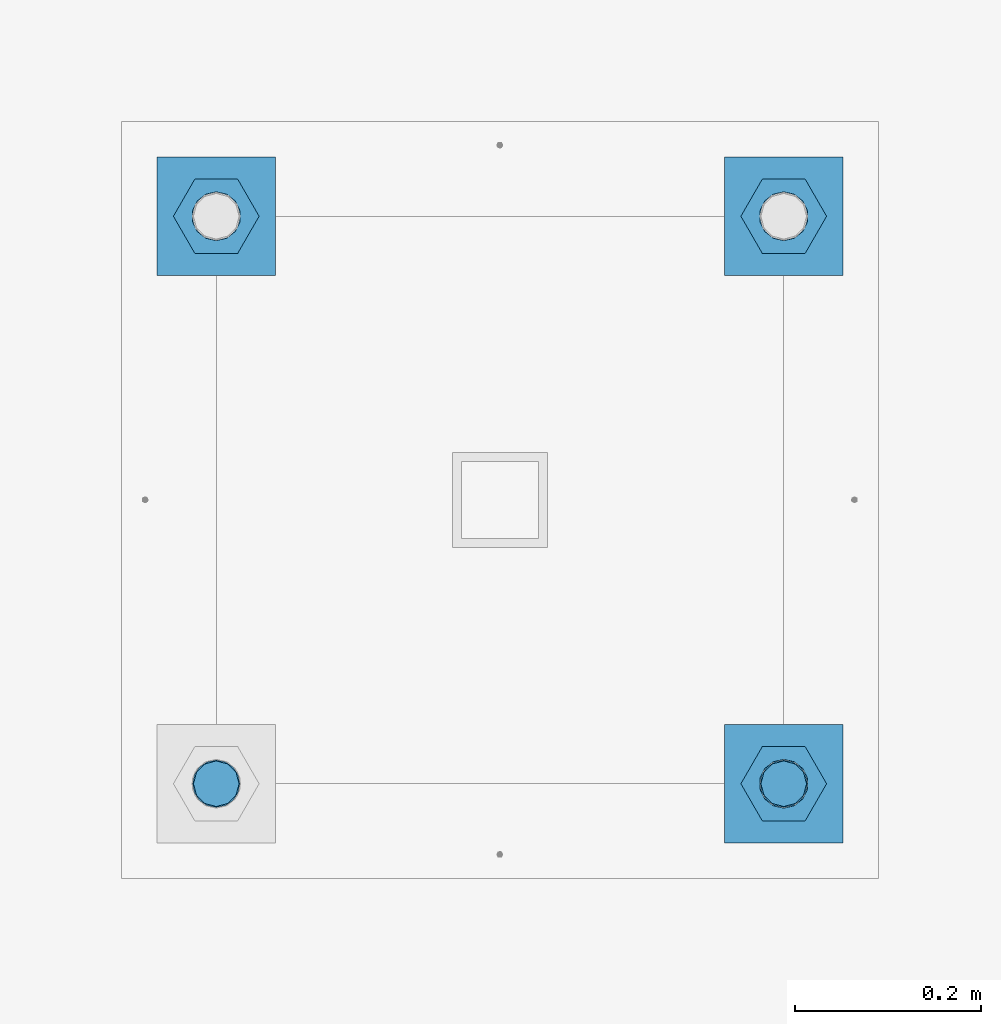
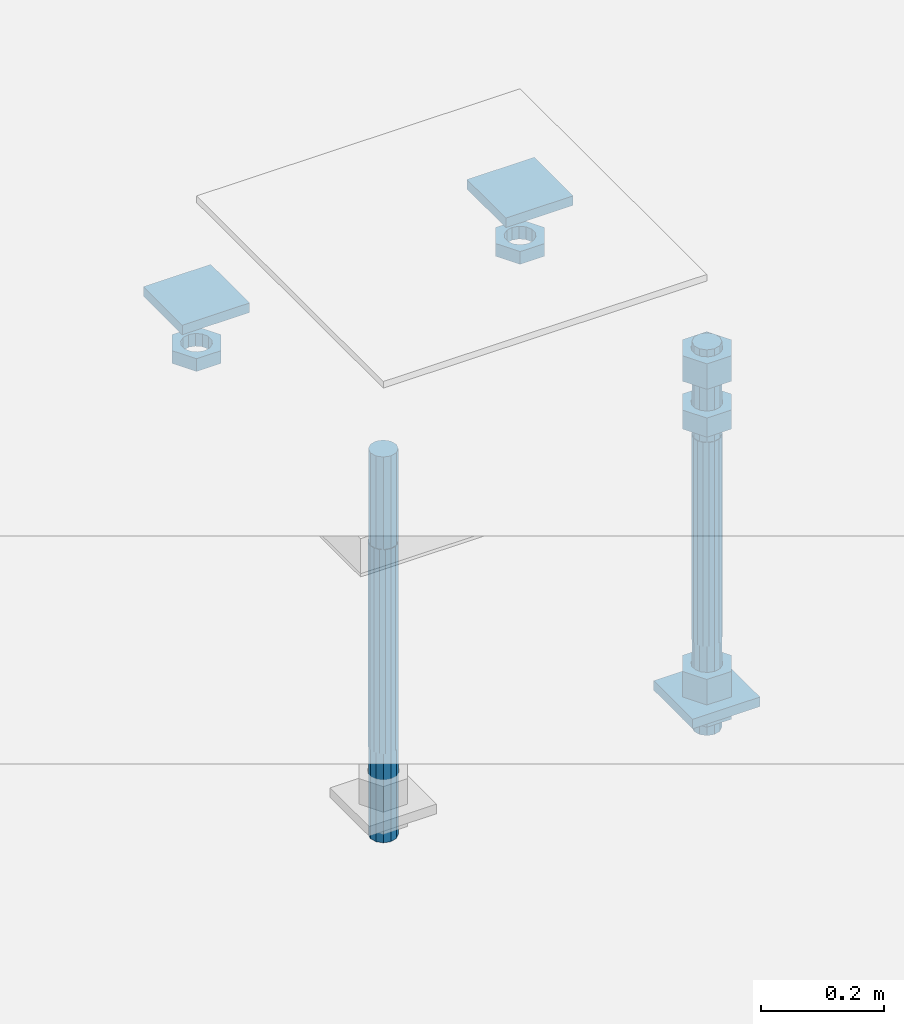
# One storey, part 2714 of 3843: 11 beams, 1 element without a shape of its own.
"""IFC2X3 building model written with IfcOpenShell, lengths in millimetres."""

from ifc_helpers import new_model, si_unit, frame, origin_with_axes, place, context, subcontext, project, spatial, faceted_brep, material, type_object, element, aggregate, save


model = new_model("IFC2X3")

# Units and contexts
model_context = context("Model", 3, precision=1e-05, world=origin_with_axes())
body_context = subcontext(model_context, "Body", "Model", "MODEL_VIEW")
ifc_project = project(units=[si_unit("LENGTHUNIT", "METRE", prefix="MILLI"), si_unit("AREAUNIT", "SQUARE_METRE"), si_unit("VOLUMEUNIT", "CUBIC_METRE"), si_unit("MASSUNIT", "GRAM", prefix="KILO"), si_unit("TIMEUNIT", "SECOND"), si_unit("PLANEANGLEUNIT", "RADIAN"), si_unit("SOLIDANGLEUNIT", "STERADIAN"), si_unit("THERMODYNAMICTEMPERATUREUNIT", "DEGREE_CELSIUS"), si_unit("LUMINOUSINTENSITYUNIT", "LUMEN")], contexts=[model_context])

# Site, building, storey
site_placement = place(None, origin_with_axes())
site = spatial("IfcSite", under=ifc_project, at=site_placement, CompositionType="ELEMENT")
building_placement = place(site_placement, origin_with_axes())
building = spatial("IfcBuilding", under=site, at=building_placement, Name="Undefined", CompositionType="ELEMENT")
storey_placement = place(building_placement, origin_with_axes())
storey = spatial("IfcBuildingStorey", under=building, at=storey_placement, Name="Undefined", CompositionType="ELEMENT", Elevation=0.0)

# Assembly, beams
assembly_placement = place(storey_placement, origin_with_axes())
assembly = element("IfcElementAssembly", 1, at=assembly_placement, inside=storey, Name="TEMPLATE", AssemblyPlace="NOTDEFINED", PredefinedType="RIGID_FRAME")
ifc_material_1 = material(Name="STEEL/A36")
beam_type_1 = type_object("IfcBeamType", PredefinedType="NOTDEFINED")
beam_1_placement = place(assembly_placement, frame((108648.5, 48869.6000015259, 29873.575), z_axis=(1.0, 0.0, 0.0), x_axis=(0.0, 1.0, 0.0)))
beam_1 = element("IfcBeam", 2, at=beam_1_placement, type_object=beam_type_1, material=ifc_material_1, Name="WASHER_PLATE", context=body_context, shape_type="Brep", body=[
    faceted_brep([(0.0, 9.52500000000146, -63.5), (0.0, 9.52500000000146, 63.5), (127.0, 9.52500000000146, 63.5), (127.0, 9.52500000000146, -63.5), (0.0, -9.52500000000146, 63.5), (127.0, -9.52500000000146, 63.5), (0.0, -9.52500000000146, -63.5), (127.0, -9.52500000000146, -63.5)], [[[0, 1, 2, 3]], [[1, 4, 5, 2]], [[4, 6, 7, 5]], [[6, 0, 3, 7]], [[5, 7, 3, 2]], [[6, 4, 1, 0]]]),
])
beam_2_placement = place(assembly_placement, frame((109258.1, 48869.6000015259, 29873.575), z_axis=(1.0, 0.0, 0.0), x_axis=(0.0, 1.0, 0.0)))
beam_2 = element("IfcBeam", 3, at=beam_2_placement, type_object=beam_type_1, material=ifc_material_1, Name="WASHER_PLATE", context=body_context, shape_type="Brep", body=[
    faceted_brep([(0.0, 9.52500000000146, -63.5), (0.0, 9.52500000000146, 63.5), (127.0, 9.52500000000146, 63.5), (127.0, 9.52500000000146, -63.5), (0.0, -9.52500000000146, 63.5), (127.0, -9.52500000000146, 63.5), (0.0, -9.52500000000146, -63.5), (127.0, -9.52500000000146, -63.5)], [[[0, 1, 2, 3]], [[1, 4, 5, 2]], [[4, 6, 7, 5]], [[6, 0, 3, 7]], [[5, 7, 3, 2]], [[6, 4, 1, 0]]]),
])
beam_3_placement = place(assembly_placement, frame((109258.1, 48260.0000015259, 29244.925), z_axis=(1.0, 0.0, 0.0), x_axis=(0.0, 1.0, 0.0)))
beam_3 = element("IfcBeam", 4, at=beam_3_placement, type_object=beam_type_1, material=ifc_material_1, Name="WASHER_PLATE", context=body_context, shape_type="Brep", body=[
    faceted_brep([(0.0, 9.52500000000146, -63.5), (0.0, 9.52500000000146, 63.5), (127.0, 9.52500000000146, 63.5), (127.0, 9.52500000000146, -63.5), (0.0, -9.52500000000146, 63.5), (127.0, -9.52500000000146, 63.5), (0.0, -9.52500000000146, -63.5), (127.0, -9.52500000000146, -63.5)], [[[0, 1, 2, 3]], [[1, 4, 5, 2]], [[4, 6, 7, 5]], [[6, 0, 3, 7]], [[5, 7, 3, 2]], [[6, 4, 1, 0]]]),
])
beam_type_2 = type_object("IfcBeamType", Name="2_HALF_NUT", PredefinedType="NOTDEFINED")
beam_4_placement = place(assembly_placement, frame((108648.5, 48933.1000015259, 29787.85), z_axis=(0.0, 1.0, 0.0), x_axis=(0.0, 0.0, -1.0)))
beam_4 = element("IfcBeam", 5, at=beam_4_placement, type_object=beam_type_2, material=ifc_material_1, Name="NUT", ObjectType="2_HALF_NUT", context=body_context, shape_type="Brep", body=[
    faceted_brep([(0.0, -46.0369987487793, 0.0), (0.0, -23.0184993743896, -39.869213104248), (25.4000000000015, -23.0184993743896, -39.869213104248), (25.4000000000015, -46.0369987487793, 0.0), (0.0, 23.0184993743896, -39.869213104248), (25.4000000000015, 23.0184993743896, -39.869213104248), (0.0, 46.0369987487793, 0.0), (25.4000000000015, 46.0369987487793, 0.0), (0.0, 23.0184993743896, 39.869213104248), (25.4000000000015, 23.0184993743896, 39.869213104248), (0.0, -23.0184993743896, 39.869213104248), (25.4000000000015, -23.0184993743896, 39.869213104248), (0.0, 0.0, 26.1940002441406), (0.0, 11.3650617044477, 23.5999013092805), (25.4000000000015, 11.3650617044477, 23.5999013092805), (25.4000000000015, 0.0, 26.1940002441406), (0.0, 20.4791109456419, 16.3316083006721), (25.4000000000015, 20.4791109456419, 16.3316083006721), (0.0, 25.5370200498292, 5.82867859874386), (25.4000000000015, 25.5370200498292, 5.82867859874386), (0.0, 25.5370200498292, -5.82867859874386), (25.4000000000015, 25.5370200498292, -5.82867859874386), (0.0, 20.4791109456419, -16.3316083006721), (25.4000000000015, 20.4791109456419, -16.3316083006721), (0.0, 11.3650617044477, -23.5999013092805), (25.4000000000015, 11.3650617044477, -23.5999013092805), (0.0, 0.0, -26.1940002441406), (25.4000000000015, 0.0, -26.1940002441406), (0.0, -11.3650617044477, -23.5999013092805), (25.4000000000015, -11.3650617044477, -23.5999013092805), (0.0, -20.4791109456419, -16.3316083006721), (25.4000000000015, -20.4791109456419, -16.3316083006721), (0.0, -25.5370200498292, -5.82867859874386), (25.4000000000015, -25.5370200498292, -5.82867859874386), (0.0, -25.5370200498292, 5.82867859874386), (25.4000000000015, -25.5370200498292, 5.82867859874386), (0.0, -20.4791109456419, 16.3316083006721), (25.4000000000015, -20.4791109456419, 16.3316083006721), (0.0, -11.3650617044477, 23.5999013092805), (25.4000000000015, -11.3650617044477, 23.5999013092805)], [[[0, 1, 2, 3]], [[1, 4, 5, 2]], [[4, 6, 7, 5]], [[6, 8, 9, 7]], [[8, 10, 11, 9]], [[10, 0, 3, 11]], [[12, 13, 14, 15]], [[13, 16, 17, 14]], [[16, 18, 19, 17]], [[18, 20, 21, 19]], [[20, 22, 23, 21]], [[22, 24, 25, 23]], [[24, 26, 27, 25]], [[26, 28, 29, 27]], [[28, 30, 31, 29]], [[30, 32, 33, 31]], [[32, 34, 35, 33]], [[34, 36, 37, 35]], [[36, 38, 39, 37]], [[38, 12, 15, 39]], [[5, 7, 9, 11, 3, 2], [17, 19, 21, 23, 25, 27, 29, 31, 33, 35, 37, 39, 15, 14]], [[10, 8, 6, 4, 1, 0], [38, 36, 34, 32, 30, 28, 26, 24, 22, 20, 18, 16, 13, 12]]]),
])
beam_5_placement = place(assembly_placement, frame((109258.1, 48933.1000015259, 29787.85), z_axis=(0.0, 1.0, 0.0), x_axis=(0.0, 0.0, -1.0)))
beam_5 = element("IfcBeam", 6, at=beam_5_placement, type_object=beam_type_2, material=ifc_material_1, Name="NUT", ObjectType="2_HALF_NUT", context=body_context, shape_type="Brep", body=[
    faceted_brep([(0.0, -46.0369987487793, 0.0), (0.0, -23.0184993743896, -39.869213104248), (25.4000000000015, -23.0184993743896, -39.869213104248), (25.4000000000015, -46.0369987487793, 0.0), (0.0, 23.0184993743896, -39.869213104248), (25.4000000000015, 23.0184993743896, -39.869213104248), (0.0, 46.0369987487793, 0.0), (25.4000000000015, 46.0369987487793, 0.0), (0.0, 23.0184993743896, 39.869213104248), (25.4000000000015, 23.0184993743896, 39.869213104248), (0.0, -23.0184993743896, 39.869213104248), (25.4000000000015, -23.0184993743896, 39.869213104248), (0.0, 0.0, 26.1940002441406), (0.0, 11.3650617044477, 23.5999013092805), (25.4000000000015, 11.3650617044477, 23.5999013092805), (25.4000000000015, 0.0, 26.1940002441406), (0.0, 20.4791109456419, 16.3316083006721), (25.4000000000015, 20.4791109456419, 16.3316083006721), (0.0, 25.5370200498292, 5.82867859874386), (25.4000000000015, 25.5370200498292, 5.82867859874386), (0.0, 25.5370200498292, -5.82867859874386), (25.4000000000015, 25.5370200498292, -5.82867859874386), (0.0, 20.4791109456419, -16.3316083006721), (25.4000000000015, 20.4791109456419, -16.3316083006721), (0.0, 11.3650617044477, -23.5999013092805), (25.4000000000015, 11.3650617044477, -23.5999013092805), (0.0, 0.0, -26.1940002441406), (25.4000000000015, 0.0, -26.1940002441406), (0.0, -11.3650617044477, -23.5999013092805), (25.4000000000015, -11.3650617044477, -23.5999013092805), (0.0, -20.4791109456419, -16.3316083006721), (25.4000000000015, -20.4791109456419, -16.3316083006721), (0.0, -25.5370200498292, -5.82867859874386), (25.4000000000015, -25.5370200498292, -5.82867859874386), (0.0, -25.5370200498292, 5.82867859874386), (25.4000000000015, -25.5370200498292, 5.82867859874386), (0.0, -20.4791109456419, 16.3316083006721), (25.4000000000015, -20.4791109456419, 16.3316083006721), (0.0, -11.3650617044477, 23.5999013092805), (25.4000000000015, -11.3650617044477, 23.5999013092805)], [[[0, 1, 2, 3]], [[1, 4, 5, 2]], [[4, 6, 7, 5]], [[6, 8, 9, 7]], [[8, 10, 11, 9]], [[10, 0, 3, 11]], [[12, 13, 14, 15]], [[13, 16, 17, 14]], [[16, 18, 19, 17]], [[18, 20, 21, 19]], [[20, 22, 23, 21]], [[22, 24, 25, 23]], [[24, 26, 27, 25]], [[26, 28, 29, 27]], [[28, 30, 31, 29]], [[30, 32, 33, 31]], [[32, 34, 35, 33]], [[34, 36, 37, 35]], [[36, 38, 39, 37]], [[38, 12, 15, 39]], [[5, 7, 9, 11, 3, 2], [17, 19, 21, 23, 25, 27, 29, 31, 33, 35, 37, 39, 15, 14]], [[10, 8, 6, 4, 1, 0], [38, 36, 34, 32, 30, 28, 26, 24, 22, 20, 18, 16, 13, 12]]]),
])
beam_6_placement = place(assembly_placement, frame((109258.1, 48323.5000015259, 29235.4), z_axis=(0.0, 1.0, 0.0), x_axis=(0.0, 0.0, -1.0)))
beam_6 = element("IfcBeam", 7, at=beam_6_placement, type_object=beam_type_2, material=ifc_material_1, Name="NUT", ObjectType="2_HALF_NUT", context=body_context, shape_type="Brep", body=[
    faceted_brep([(0.0, -46.0369987487793, 0.0), (0.0, -23.0184993743896, -39.869213104248), (25.4000000000015, -23.0184993743896, -39.869213104248), (25.4000000000015, -46.0369987487793, 0.0), (0.0, 23.0184993743896, -39.869213104248), (25.4000000000015, 23.0184993743896, -39.869213104248), (0.0, 46.0369987487793, 0.0), (25.4000000000015, 46.0369987487793, 0.0), (0.0, 23.0184993743896, 39.869213104248), (25.4000000000015, 23.0184993743896, 39.869213104248), (0.0, -23.0184993743896, 39.869213104248), (25.4000000000015, -23.0184993743896, 39.869213104248), (0.0, 0.0, 26.1940002441406), (0.0, 11.3650617044477, 23.5999013092805), (25.4000000000015, 11.3650617044477, 23.5999013092805), (25.4000000000015, 0.0, 26.1940002441406), (0.0, 20.4791109456419, 16.3316083006721), (25.4000000000015, 20.4791109456419, 16.3316083006721), (0.0, 25.5370200498292, 5.82867859874386), (25.4000000000015, 25.5370200498292, 5.82867859874386), (0.0, 25.5370200498292, -5.82867859874386), (25.4000000000015, 25.5370200498292, -5.82867859874386), (0.0, 20.4791109456419, -16.3316083006721), (25.4000000000015, 20.4791109456419, -16.3316083006721), (0.0, 11.3650617044477, -23.5999013092805), (25.4000000000015, 11.3650617044477, -23.5999013092805), (0.0, 0.0, -26.1940002441406), (25.4000000000015, 0.0, -26.1940002441406), (0.0, -11.3650617044477, -23.5999013092805), (25.4000000000015, -11.3650617044477, -23.5999013092805), (0.0, -20.4791109456419, -16.3316083006721), (25.4000000000015, -20.4791109456419, -16.3316083006721), (0.0, -25.5370200498292, -5.82867859874386), (25.4000000000015, -25.5370200498292, -5.82867859874386), (0.0, -25.5370200498292, 5.82867859874386), (25.4000000000015, -25.5370200498292, 5.82867859874386), (0.0, -20.4791109456419, 16.3316083006721), (25.4000000000015, -20.4791109456419, 16.3316083006721), (0.0, -11.3650617044477, 23.5999013092805), (25.4000000000015, -11.3650617044477, 23.5999013092805)], [[[0, 1, 2, 3]], [[1, 4, 5, 2]], [[4, 6, 7, 5]], [[6, 8, 9, 7]], [[8, 10, 11, 9]], [[10, 0, 3, 11]], [[12, 13, 14, 15]], [[13, 16, 17, 14]], [[16, 18, 19, 17]], [[18, 20, 21, 19]], [[20, 22, 23, 21]], [[22, 24, 25, 23]], [[24, 26, 27, 25]], [[26, 28, 29, 27]], [[28, 30, 31, 29]], [[30, 32, 33, 31]], [[32, 34, 35, 33]], [[34, 36, 37, 35]], [[36, 38, 39, 37]], [[38, 12, 15, 39]], [[5, 7, 9, 11, 3, 2], [17, 19, 21, 23, 25, 27, 29, 31, 33, 35, 37, 39, 15, 14]], [[10, 8, 6, 4, 1, 0], [38, 36, 34, 32, 30, 28, 26, 24, 22, 20, 18, 16, 13, 12]]]),
])
beam_type_3 = type_object("IfcBeamType", Name="2_HEAVY_HEX_NUT", PredefinedType="NOTDEFINED")
beam_7_placement = place(assembly_placement, frame((109258.1, 48323.5000015259, 29825.95), z_axis=(0.0, 1.0, 0.0), x_axis=(0.0, 0.0, -1.0)))
beam_7 = element("IfcBeam", 8, at=beam_7_placement, type_object=beam_type_3, material=ifc_material_1, Name="NUT", ObjectType="2_HEAVY_HEX_NUT", context=body_context, shape_type="Brep", body=[
    faceted_brep([(0.0, -46.0369987487793, 0.0), (0.0, -23.0184993743896, -39.869213104248), (38.0999999999985, -23.0184993743896, -39.869213104248), (38.0999999999985, -46.0369987487793, 0.0), (0.0, 23.0184993743896, -39.869213104248), (38.0999999999985, 23.0184993743896, -39.869213104248), (0.0, 46.0369987487793, 0.0), (38.0999999999985, 46.0369987487793, 0.0), (0.0, 23.0184993743896, 39.869213104248), (38.0999999999985, 23.0184993743896, 39.869213104248), (0.0, -23.0184993743896, 39.869213104248), (38.0999999999985, -23.0184993743896, 39.869213104248), (0.0, 0.0, 26.1940002441406), (0.0, 11.3650617044477, 23.5999013092805), (38.0999999999985, 11.3650617044477, 23.5999013092805), (38.0999999999985, 0.0, 26.1940002441406), (0.0, 20.4791109456419, 16.3316083006721), (38.0999999999985, 20.4791109456419, 16.3316083006721), (0.0, 25.5370200498292, 5.82867859874386), (38.0999999999985, 25.5370200498292, 5.82867859874386), (0.0, 25.5370200498292, -5.82867859874386), (38.0999999999985, 25.5370200498292, -5.82867859874386), (0.0, 20.4791109456419, -16.3316083006721), (38.0999999999985, 20.4791109456419, -16.3316083006721), (0.0, 11.3650617044477, -23.5999013092805), (38.0999999999985, 11.3650617044477, -23.5999013092805), (0.0, 0.0, -26.1940002441406), (38.0999999999985, 0.0, -26.1940002441406), (0.0, -11.3650617044477, -23.5999013092805), (38.0999999999985, -11.3650617044477, -23.5999013092805), (0.0, -20.4791109456419, -16.3316083006721), (38.0999999999985, -20.4791109456419, -16.3316083006721), (0.0, -25.5370200498292, -5.82867859874386), (38.0999999999985, -25.5370200498292, -5.82867859874386), (0.0, -25.5370200498292, 5.82867859874386), (38.0999999999985, -25.5370200498292, 5.82867859874386), (0.0, -20.4791109456419, 16.3316083006721), (38.0999999999985, -20.4791109456419, 16.3316083006721), (0.0, -11.3650617044477, 23.5999013092805), (38.0999999999985, -11.3650617044477, 23.5999013092805)], [[[0, 1, 2, 3]], [[1, 4, 5, 2]], [[4, 6, 7, 5]], [[6, 8, 9, 7]], [[8, 10, 11, 9]], [[10, 0, 3, 11]], [[12, 13, 14, 15]], [[13, 16, 17, 14]], [[16, 18, 19, 17]], [[18, 20, 21, 19]], [[20, 22, 23, 21]], [[22, 24, 25, 23]], [[24, 26, 27, 25]], [[26, 28, 29, 27]], [[28, 30, 31, 29]], [[30, 32, 33, 31]], [[32, 34, 35, 33]], [[34, 36, 37, 35]], [[36, 38, 39, 37]], [[38, 12, 15, 39]], [[5, 7, 9, 11, 3, 2], [17, 19, 21, 23, 25, 27, 29, 31, 33, 35, 37, 39, 15, 14]], [[10, 8, 6, 4, 1, 0], [38, 36, 34, 32, 30, 28, 26, 24, 22, 20, 18, 16, 13, 12]]]),
])
beam_8_placement = place(assembly_placement, frame((109258.1, 48323.5000015259, 29933.9), z_axis=(0.0, 1.0, 0.0), x_axis=(0.0, 0.0, -1.0)))
beam_8 = element("IfcBeam", 9, at=beam_8_placement, type_object=beam_type_3, material=ifc_material_1, Name="NUT", ObjectType="2_HEAVY_HEX_NUT", context=body_context, shape_type="Brep", body=[
    faceted_brep([(0.0, -46.0369987487793, 0.0), (0.0, -23.0184993743896, -39.869213104248), (50.7999999999993, -23.0184993743896, -39.869213104248), (50.7999999999993, -46.0369987487793, 0.0), (0.0, 23.0184993743896, -39.869213104248), (50.7999999999993, 23.0184993743896, -39.869213104248), (0.0, 46.0369987487793, 0.0), (50.7999999999993, 46.0369987487793, 0.0), (0.0, 23.0184993743896, 39.869213104248), (50.7999999999993, 23.0184993743896, 39.869213104248), (0.0, -23.0184993743896, 39.869213104248), (50.7999999999993, -23.0184993743896, 39.869213104248), (0.0, 0.0, 26.1940002441406), (0.0, 11.3650617044477, 23.5999013092805), (50.7999999999993, 11.3650617044477, 23.5999013092805), (50.7999999999993, 0.0, 26.1940002441406), (0.0, 20.4791109456419, 16.3316083006721), (50.7999999999993, 20.4791109456419, 16.3316083006721), (0.0, 25.5370200498292, 5.82867859874386), (50.7999999999993, 25.5370200498292, 5.82867859874386), (0.0, 25.5370200498292, -5.82867859874386), (50.7999999999993, 25.5370200498292, -5.82867859874386), (0.0, 20.4791109456419, -16.3316083006721), (50.7999999999993, 20.4791109456419, -16.3316083006721), (0.0, 11.3650617044477, -23.5999013092805), (50.7999999999993, 11.3650617044477, -23.5999013092805), (0.0, 0.0, -26.1940002441406), (50.7999999999993, 0.0, -26.1940002441406), (0.0, -11.3650617044477, -23.5999013092805), (50.7999999999993, -11.3650617044477, -23.5999013092805), (0.0, -20.4791109456419, -16.3316083006721), (50.7999999999993, -20.4791109456419, -16.3316083006721), (0.0, -25.5370200498292, -5.82867859874386), (50.7999999999993, -25.5370200498292, -5.82867859874386), (0.0, -25.5370200498292, 5.82867859874386), (50.7999999999993, -25.5370200498292, 5.82867859874386), (0.0, -20.4791109456419, 16.3316083006721), (50.7999999999993, -20.4791109456419, 16.3316083006721), (0.0, -11.3650617044477, 23.5999013092805), (50.7999999999993, -11.3650617044477, 23.5999013092805)], [[[0, 1, 2, 3]], [[1, 4, 5, 2]], [[4, 6, 7, 5]], [[6, 8, 9, 7]], [[8, 10, 11, 9]], [[10, 0, 3, 11]], [[12, 13, 14, 15]], [[13, 16, 17, 14]], [[16, 18, 19, 17]], [[18, 20, 21, 19]], [[20, 22, 23, 21]], [[22, 24, 25, 23]], [[24, 26, 27, 25]], [[26, 28, 29, 27]], [[28, 30, 31, 29]], [[30, 32, 33, 31]], [[32, 34, 35, 33]], [[34, 36, 37, 35]], [[36, 38, 39, 37]], [[38, 12, 15, 39]], [[5, 7, 9, 11, 3, 2], [17, 19, 21, 23, 25, 27, 29, 31, 33, 35, 37, 39, 15, 14]], [[10, 8, 6, 4, 1, 0], [38, 36, 34, 32, 30, 28, 26, 24, 22, 20, 18, 16, 13, 12]]]),
])
beam_9_placement = place(assembly_placement, frame((109258.1, 48323.5000015259, 29305.25), z_axis=(0.0, 1.0, 0.0), x_axis=(0.0, 0.0, -1.0)))
beam_9 = element("IfcBeam", 10, at=beam_9_placement, type_object=beam_type_3, material=ifc_material_1, Name="NUT", ObjectType="2_HEAVY_HEX_NUT", context=body_context, shape_type="Brep", body=[
    faceted_brep([(0.0, -46.0369987487793, 0.0), (0.0, -23.0184993743896, -39.869213104248), (50.7999999999993, -23.0184993743896, -39.869213104248), (50.7999999999993, -46.0369987487793, 0.0), (0.0, 23.0184993743896, -39.869213104248), (50.7999999999993, 23.0184993743896, -39.869213104248), (0.0, 46.0369987487793, 0.0), (50.7999999999993, 46.0369987487793, 0.0), (0.0, 23.0184993743896, 39.869213104248), (50.7999999999993, 23.0184993743896, 39.869213104248), (0.0, -23.0184993743896, 39.869213104248), (50.7999999999993, -23.0184993743896, 39.869213104248), (0.0, 0.0, 26.1940002441406), (0.0, 11.3650617044477, 23.5999013092805), (50.7999999999993, 11.3650617044477, 23.5999013092805), (50.7999999999993, 0.0, 26.1940002441406), (0.0, 20.4791109456419, 16.3316083006721), (50.7999999999993, 20.4791109456419, 16.3316083006721), (0.0, 25.5370200498292, 5.82867859874386), (50.7999999999993, 25.5370200498292, 5.82867859874386), (0.0, 25.5370200498292, -5.82867859874386), (50.7999999999993, 25.5370200498292, -5.82867859874386), (0.0, 20.4791109456419, -16.3316083006721), (50.7999999999993, 20.4791109456419, -16.3316083006721), (0.0, 11.3650617044477, -23.5999013092805), (50.7999999999993, 11.3650617044477, -23.5999013092805), (0.0, 0.0, -26.1940002441406), (50.7999999999993, 0.0, -26.1940002441406), (0.0, -11.3650617044477, -23.5999013092805), (50.7999999999993, -11.3650617044477, -23.5999013092805), (0.0, -20.4791109456419, -16.3316083006721), (50.7999999999993, -20.4791109456419, -16.3316083006721), (0.0, -25.5370200498292, -5.82867859874386), (50.7999999999993, -25.5370200498292, -5.82867859874386), (0.0, -25.5370200498292, 5.82867859874386), (50.7999999999993, -25.5370200498292, 5.82867859874386), (0.0, -20.4791109456419, 16.3316083006721), (50.7999999999993, -20.4791109456419, 16.3316083006721), (0.0, -11.3650617044477, 23.5999013092805), (50.7999999999993, -11.3650617044477, 23.5999013092805)], [[[0, 1, 2, 3]], [[1, 4, 5, 2]], [[4, 6, 7, 5]], [[6, 8, 9, 7]], [[8, 10, 11, 9]], [[10, 0, 3, 11]], [[12, 13, 14, 15]], [[13, 16, 17, 14]], [[16, 18, 19, 17]], [[18, 20, 21, 19]], [[20, 22, 23, 21]], [[22, 24, 25, 23]], [[24, 26, 27, 25]], [[26, 28, 29, 27]], [[28, 30, 31, 29]], [[30, 32, 33, 31]], [[32, 34, 35, 33]], [[34, 36, 37, 35]], [[36, 38, 39, 37]], [[38, 12, 15, 39]], [[5, 7, 9, 11, 3, 2], [17, 19, 21, 23, 25, 27, 29, 31, 33, 35, 37, 39, 15, 14]], [[10, 8, 6, 4, 1, 0], [38, 36, 34, 32, 30, 28, 26, 24, 22, 20, 18, 16, 13, 12]]]),
])
ifc_material_2 = material()
beam_type_4 = type_object("IfcBeamType", PredefinedType="NOTDEFINED")
beam_10_placement = place(assembly_placement, frame((109258.1, 48323.5000015259, 29762.45), z_axis=(0.0, 1.0, 0.0), x_axis=(0.0, 0.0, -1.0)))
beam_10 = element("IfcBeam", 11, at=beam_10_placement, type_object=beam_type_4, material=ifc_material_2, Name="ANCHOR_ROD", context=body_context, shape_type="Brep", body=[
    faceted_brep([(-184.150000000001, -21.217622392709, 12.25), (-184.150000000001, -12.2499999999854, 21.2176223927163), (-184.150000000001, 1.45519152283669e-11, 24.5), (-184.150000000001, 12.2500000000146, 21.2176223927163), (-184.150000000001, 21.2176223927381, 12.25), (-184.150000000001, 24.5000000000146, 0.0), (-184.150000000001, 21.2176223927381, -12.25), (-184.150000000001, 12.2500000000146, -21.2176223927163), (-184.150000000001, 1.45519152283669e-11, -24.5), (-184.150000000001, -12.2499999999854, -21.2176223927163), (-184.150000000001, -21.217622392709, -12.25), (-184.150000000001, -24.4999999999854, 0.0), (0.0, 24.5000000000146, 0.0), (0.0, 21.2176223927381, -12.25), (0.0, 12.2500000000146, -21.2176223927163), (0.0, 1.45519152283669e-11, -24.5), (0.0, -12.2499999999854, -21.2176223927163), (0.0, -21.217622392709, -12.25), (0.0, -24.4999999999854, 0.0), (0.0, -21.217622392709, 12.25), (0.0, -12.2499999999854, 21.2176223927163), (0.0, 1.45519152283669e-11, 24.5), (0.0, 12.2500000000146, 21.2176223927163), (0.0, 21.2176223927381, 12.25), (0.0, -23.4665401257807, 9.72015918207035), (0.0, -17.9605122421344, 17.9605122421417), (0.0, -9.72015918207762, 23.466540125788), (0.0, 0.0, 25.4000000000015), (0.0, 9.72015918207762, 23.466540125788), (0.0, 17.9605122421344, 17.9605122421417), (0.0, 23.4665401257807, 9.72015918207035), (0.0, 25.3999996185303, 0.0), (0.0, 23.4665401257807, -9.72015918207035), (0.0, 17.9605122421344, -17.9605122421417), (0.0, 9.72015918207762, -23.466540125788), (0.0, 0.0, -25.4000000000015), (0.0, -9.72015918207762, -23.466540125788), (0.0, -17.9605122421344, -17.9605122421417), (0.0, -23.4665401257807, -9.72015918207035), (0.0, -25.3999996185303, 0.0), (406.399999999998, -25.3999999999942, 0.0), (406.399999999998, -23.4665401257807, 9.72015918207035), (406.399999999998, -17.9605122421344, 17.9605122421417), (406.399999999998, -9.72015918207762, 23.466540125788), (406.399999999998, 0.0, 25.4000000000015), (406.399999999998, 9.72015918207762, 23.466540125788), (406.399999999998, 17.9605122421344, 17.9605122421417), (406.399999999998, 23.4665401257807, 9.72015918207035), (406.399999999998, 25.3999999999942, 0.0), (406.399999999998, 23.4665401257807, -9.72015918207035), (406.399999999998, 17.9605122421344, -17.9605122421417), (406.399999999998, 9.72015918207762, -23.466540125788), (406.399999999998, 0.0, -25.4000000000015), (406.399999999998, -9.72015918207762, -23.466540125788), (406.399999999998, -17.9605122421344, -17.9605122421417), (406.399999999998, -23.4665401257807, -9.72015918207035), (406.399999999998, -12.2499999999854, 21.2176223927163), (406.399999999998, 1.45519152283669e-11, 24.5), (406.399999999998, 12.2500000000146, 21.2176223927163), (406.399999999998, 21.2176223927381, 12.25), (406.399999999998, 24.5000000000146, 0.0), (406.399999999998, 21.2176223927381, -12.25), (406.399999999998, 12.2500000000146, -21.2176223927163), (406.399999999998, 1.45519152283669e-11, -24.5), (406.399999999998, -12.2499999999854, -21.2176223927163), (406.399999999998, -21.217622392709, -12.25), (406.399999999998, -24.4999999999854, 0.0), (406.399999999998, -21.217622392709, 12.25), (584.200000000001, -12.2499999999854, -21.2176223927163), (584.200000000001, 1.45519152283669e-11, -24.5), (584.200000000001, 12.2500000000146, -21.2176223927163), (584.200000000001, 21.2176223927381, -12.25), (584.200000000001, 24.5000000000146, 0.0), (584.200000000001, 21.2176223927381, 12.25), (584.200000000001, 12.2500000000146, 21.2176223927163), (584.200000000001, 1.45519152283669e-11, 24.5), (584.200000000001, -12.2499999999854, 21.2176223927163), (584.200000000001, -21.217622392709, 12.25), (584.200000000001, -24.4999999999854, 0.0), (584.200000000001, -21.217622392709, -12.25)], [[[0, 1, 2, 3, 4, 5, 6, 7, 8, 9, 10, 11]], [[6, 5, 12, 13]], [[7, 6, 13, 14]], [[8, 7, 14, 15]], [[9, 8, 15, 16]], [[10, 9, 16, 17]], [[11, 10, 17, 18]], [[0, 11, 18, 19]], [[1, 0, 19, 20]], [[2, 1, 20, 21]], [[3, 2, 21, 22]], [[4, 3, 22, 23]], [[5, 4, 23, 12]], [[24, 25, 26, 27, 28, 29, 30, 31, 32, 33, 34, 35, 36, 37, 38, 39], [22, 21, 20, 19, 18, 17, 16, 15, 14, 13, 12, 23]], [[24, 39, 40, 41]], [[25, 24, 41, 42]], [[26, 25, 42, 43]], [[27, 26, 43, 44]], [[28, 27, 44, 45]], [[29, 28, 45, 46]], [[30, 29, 46, 47]], [[31, 30, 47, 48]], [[32, 31, 48, 49]], [[33, 32, 49, 50]], [[34, 33, 50, 51]], [[35, 34, 51, 52]], [[36, 35, 52, 53]], [[37, 36, 53, 54]], [[38, 37, 54, 55]], [[39, 38, 55, 40]], [[54, 53, 52, 51, 50, 49, 48, 47, 46, 45, 44, 43, 42, 41, 40, 55], [56, 57, 58, 59, 60, 61, 62, 63, 64, 65, 66, 67]], [[68, 69, 70, 71, 72, 73, 74, 75, 76, 77, 78, 79]], [[76, 75, 57, 56]], [[77, 76, 56, 67]], [[78, 77, 67, 66]], [[79, 78, 66, 65]], [[68, 79, 65, 64]], [[69, 68, 64, 63]], [[70, 69, 63, 62]], [[71, 70, 62, 61]], [[72, 71, 61, 60]], [[73, 72, 60, 59]], [[74, 73, 59, 58]], [[75, 74, 58, 57]]]),
])
beam_11_placement = place(assembly_placement, frame((108648.5, 48323.5000015259, 29762.45), z_axis=(0.0, 1.0, 0.0), x_axis=(0.0, 0.0, -1.0)))
beam_11 = element("IfcBeam", 12, at=beam_11_placement, type_object=beam_type_4, material=ifc_material_2, Name="ANCHOR_ROD", context=body_context, shape_type="Brep", body=[
    faceted_brep([(-184.150000000001, -21.217622392709, 12.25), (-184.150000000001, -12.2499999999854, 21.2176223927163), (-184.150000000001, 1.45519152283669e-11, 24.5), (-184.150000000001, 12.2500000000146, 21.2176223927163), (-184.150000000001, 21.2176223927381, 12.25), (-184.150000000001, 24.5000000000146, 0.0), (-184.150000000001, 21.2176223927381, -12.25), (-184.150000000001, 12.2500000000146, -21.2176223927163), (-184.150000000001, 1.45519152283669e-11, -24.5), (-184.150000000001, -12.2499999999854, -21.2176223927163), (-184.150000000001, -21.217622392709, -12.25), (-184.150000000001, -24.4999999999854, 0.0), (0.0, 24.5000000000146, 0.0), (0.0, 21.2176223927381, -12.25), (0.0, 12.2500000000146, -21.2176223927163), (0.0, 1.45519152283669e-11, -24.5), (0.0, -12.2499999999854, -21.2176223927163), (0.0, -21.217622392709, -12.25), (0.0, -24.4999999999854, 0.0), (0.0, -21.217622392709, 12.25), (0.0, -12.2499999999854, 21.2176223927163), (0.0, 1.45519152283669e-11, 24.5), (0.0, 12.2500000000146, 21.2176223927163), (0.0, 21.2176223927381, 12.25), (0.0, -23.4665401257807, 9.72015918207035), (0.0, -17.9605122421344, 17.9605122421417), (0.0, -9.72015918207762, 23.466540125788), (0.0, 0.0, 25.4000000000015), (0.0, 9.72015918207762, 23.466540125788), (0.0, 17.9605122421344, 17.9605122421417), (0.0, 23.4665401257807, 9.72015918207035), (0.0, 25.3999996185303, 0.0), (0.0, 23.4665401257807, -9.72015918207035), (0.0, 17.9605122421344, -17.9605122421417), (0.0, 9.72015918207762, -23.466540125788), (0.0, 0.0, -25.4000000000015), (0.0, -9.72015918207762, -23.466540125788), (0.0, -17.9605122421344, -17.9605122421417), (0.0, -23.4665401257807, -9.72015918207035), (0.0, -25.3999996185303, 0.0), (406.399999999998, -25.3999999999942, 0.0), (406.399999999998, -23.4665401257807, 9.72015918207035), (406.399999999998, -17.9605122421344, 17.9605122421417), (406.399999999998, -9.72015918207762, 23.466540125788), (406.399999999998, 0.0, 25.4000000000015), (406.399999999998, 9.72015918207762, 23.466540125788), (406.399999999998, 17.9605122421344, 17.9605122421417), (406.399999999998, 23.4665401257807, 9.72015918207035), (406.399999999998, 25.3999999999942, 0.0), (406.399999999998, 23.4665401257807, -9.72015918207035), (406.399999999998, 17.9605122421344, -17.9605122421417), (406.399999999998, 9.72015918207762, -23.466540125788), (406.399999999998, 0.0, -25.4000000000015), (406.399999999998, -9.72015918207762, -23.466540125788), (406.399999999998, -17.9605122421344, -17.9605122421417), (406.399999999998, -23.4665401257807, -9.72015918207035), (406.399999999998, -12.2499999999854, 21.2176223927163), (406.399999999998, 1.45519152283669e-11, 24.5), (406.399999999998, 12.2500000000146, 21.2176223927163), (406.399999999998, 21.2176223927381, 12.25), (406.399999999998, 24.5000000000146, 0.0), (406.399999999998, 21.2176223927381, -12.25), (406.399999999998, 12.2500000000146, -21.2176223927163), (406.399999999998, 1.45519152283669e-11, -24.5), (406.399999999998, -12.2499999999854, -21.2176223927163), (406.399999999998, -21.217622392709, -12.25), (406.399999999998, -24.4999999999854, 0.0), (406.399999999998, -21.217622392709, 12.25), (584.200000000001, -12.2499999999854, -21.2176223927163), (584.200000000001, 1.45519152283669e-11, -24.5), (584.200000000001, 12.2500000000146, -21.2176223927163), (584.200000000001, 21.2176223927381, -12.25), (584.200000000001, 24.5000000000146, 0.0), (584.200000000001, 21.2176223927381, 12.25), (584.200000000001, 12.2500000000146, 21.2176223927163), (584.200000000001, 1.45519152283669e-11, 24.5), (584.200000000001, -12.2499999999854, 21.2176223927163), (584.200000000001, -21.217622392709, 12.25), (584.200000000001, -24.4999999999854, 0.0), (584.200000000001, -21.217622392709, -12.25)], [[[0, 1, 2, 3, 4, 5, 6, 7, 8, 9, 10, 11]], [[6, 5, 12, 13]], [[7, 6, 13, 14]], [[8, 7, 14, 15]], [[9, 8, 15, 16]], [[10, 9, 16, 17]], [[11, 10, 17, 18]], [[0, 11, 18, 19]], [[1, 0, 19, 20]], [[2, 1, 20, 21]], [[3, 2, 21, 22]], [[4, 3, 22, 23]], [[5, 4, 23, 12]], [[24, 25, 26, 27, 28, 29, 30, 31, 32, 33, 34, 35, 36, 37, 38, 39], [22, 21, 20, 19, 18, 17, 16, 15, 14, 13, 12, 23]], [[24, 39, 40, 41]], [[25, 24, 41, 42]], [[26, 25, 42, 43]], [[27, 26, 43, 44]], [[28, 27, 44, 45]], [[29, 28, 45, 46]], [[30, 29, 46, 47]], [[31, 30, 47, 48]], [[32, 31, 48, 49]], [[33, 32, 49, 50]], [[34, 33, 50, 51]], [[35, 34, 51, 52]], [[36, 35, 52, 53]], [[37, 36, 53, 54]], [[38, 37, 54, 55]], [[39, 38, 55, 40]], [[54, 53, 52, 51, 50, 49, 48, 47, 46, 45, 44, 43, 42, 41, 40, 55], [56, 57, 58, 59, 60, 61, 62, 63, 64, 65, 66, 67]], [[68, 69, 70, 71, 72, 73, 74, 75, 76, 77, 78, 79]], [[76, 75, 57, 56]], [[77, 76, 56, 67]], [[78, 77, 67, 66]], [[79, 78, 66, 65]], [[68, 79, 65, 64]], [[69, 68, 64, 63]], [[70, 69, 63, 62]], [[71, 70, 62, 61]], [[72, 71, 61, 60]], [[73, 72, 60, 59]], [[74, 73, 59, 58]], [[75, 74, 58, 57]]]),
])
aggregate(assembly, [beam_4, beam_5, beam_1, beam_2, beam_10, beam_7, beam_8, beam_9, beam_6, beam_3, beam_11])

save(model, "model.ifc")
